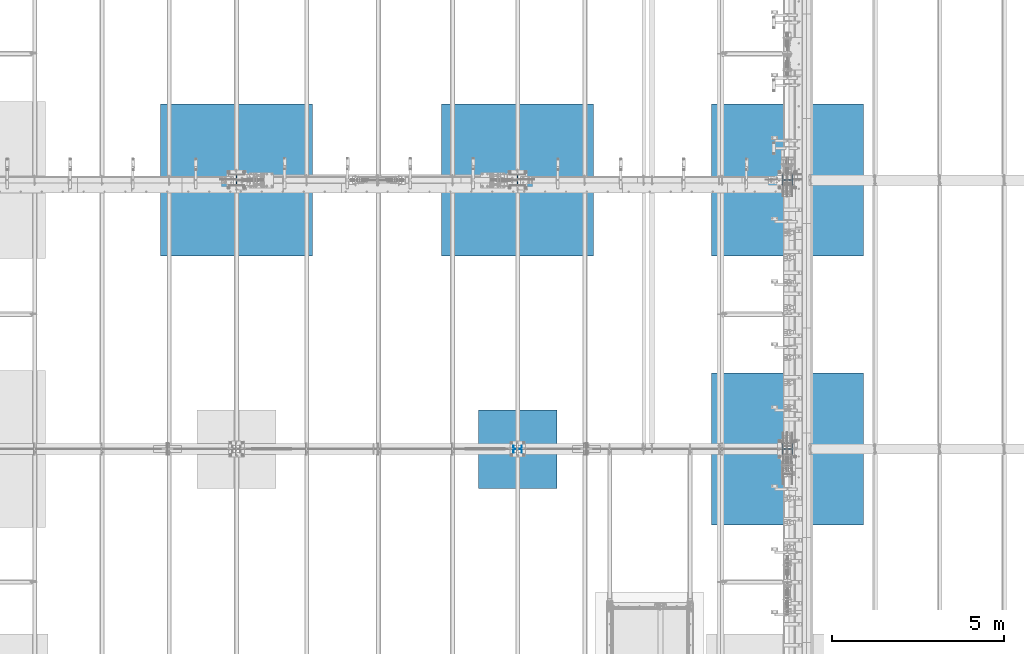
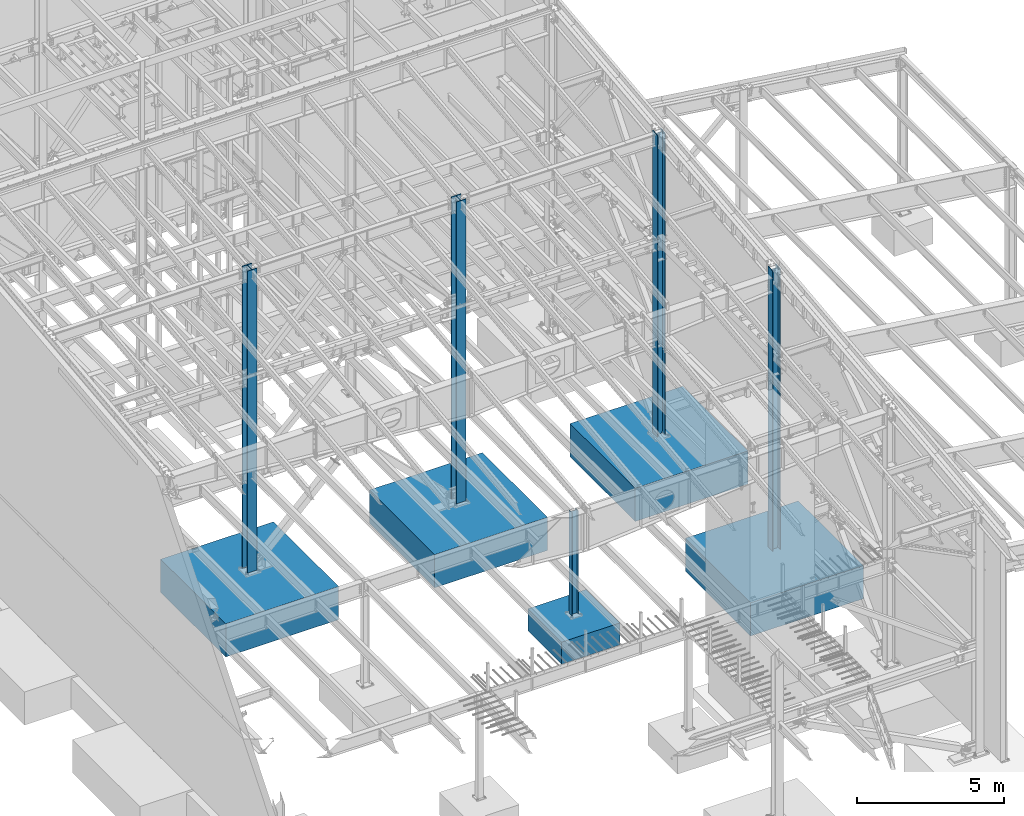
# One storey, part 359 of 1179: 10 columns, 10 elements without a shape of their own.
"""IFC2X3 building model written with IfcOpenShell, lengths in millimetres."""

import ifcopenshell
import ifcopenshell.guid

model = None  # the IFC model being written
_history = None  # IfcOwnerHistory: only IFC2X3 demands one
_inside = {}  # id of a spatial element -> (the spatial element, [elements in it])
_under = {}  # id of a project, library or spatial element -> (it, [spatial elements below it])
_declared = {}  # id of a project -> (the project, [libraries it declares])
_typed = {}  # id of a type object -> (the type object, [elements of that type])
_made_of = {}  # id of a material, layer set ... -> (it, [elements and type objects made of it])


def new_model(schema):
    """Start an empty IFC model of exactly this schema.

    Asked for "IFC4X3", IfcOpenShell would pick the latest addendum, in which some entities
    have other attributes; the version numbers below select the first issue.
    IFC2X3 requires an IfcOwnerHistory on every rooted entity: one is made here for all.
    """
    global model, _history
    if schema == "IFC4X3":
        model = ifcopenshell.file(schema_version=(4, 3, 0, 0))
    else:
        model = ifcopenshell.file(schema=schema)
    _inside.clear()
    _under.clear()
    _declared.clear()
    _typed.clear()
    _made_of.clear()
    _history = None
    if model.schema == "IFC2X3":
        org = make("IfcOrganization", Name="unknown")
        user = make(
            "IfcPersonAndOrganization",
            ThePerson=make("IfcPerson", FamilyName="unknown"),
            TheOrganization=org,
        )
        app = make(
            "IfcApplication",
            ApplicationDeveloper=org,
            Version="unknown",
            ApplicationFullName="unknown",
            ApplicationIdentifier="unknown",
        )
        _history = make(
            "IfcOwnerHistory",
            OwningUser=user,
            OwningApplication=app,
            ChangeAction="ADDED",
            CreationDate=0,
        )
    return model


def make(cls, **values):
    """One entity of the class cls with the attributes given. An attribute that is None is left unset."""
    return model.create_entity(
        cls, **{name: value for name, value in values.items() if value is not None}
    )


def rooted(cls, **values):
    """An entity with a GlobalId (a new one), such as an element, a storey or a relation."""
    return make(cls, GlobalId=ifcopenshell.guid.new(), OwnerHistory=_history, **values)


def si_unit(unit_type, name, prefix=None):
    """IfcSIUnit, for example si_unit("LENGTHUNIT", "METRE", prefix="MILLI")."""
    return make("IfcSIUnit", UnitType=unit_type, Prefix=prefix, Name=name)


def assignment(units):
    """IfcUnitAssignment: the units of a project."""
    return None if units is None else make("IfcUnitAssignment", Units=units)


def point(xyz):
    """IfcCartesianPoint."""
    return None if xyz is None else make("IfcCartesianPoint", Coordinates=xyz)


def direction(xyz):
    """IfcDirection."""
    return None if xyz is None else make("IfcDirection", DirectionRatios=xyz)


def frame(location, z_axis=None, x_axis=None):
    """IfcAxis2Placement3D, a coordinate frame: its origin and axes. An axis left out is left unset."""
    return make(
        "IfcAxis2Placement3D",
        Location=point(location),
        Axis=direction(z_axis),
        RefDirection=direction(x_axis),
    )


def origin_with_axes():
    """The frame at (0, 0, 0) with the z axis (0, 0, 1) and the x axis (1, 0, 0) written out."""
    return frame((0.0, 0.0, 0.0), z_axis=(0.0, 0.0, 1.0), x_axis=(1.0, 0.0, 0.0))


def place(relative_to, where):
    """IfcLocalPlacement: puts the frame where relative to a parent placement (None: the world)."""
    return make(
        "IfcLocalPlacement", PlacementRelTo=relative_to, RelativePlacement=where
    )


def context(
    kind, dimensions, precision=None, world=None, true_north=None, identifier=None
):
    """IfcGeometricRepresentationContext, for example the 3D "Model" context."""
    return make(
        "IfcGeometricRepresentationContext",
        ContextIdentifier=identifier,
        ContextType=kind,
        CoordinateSpaceDimension=dimensions,
        Precision=precision,
        WorldCoordinateSystem=world,
        TrueNorth=true_north,
    )


def subcontext(parent, identifier, kind, view, scale=None):
    """IfcGeometricRepresentationSubContext, for example "Body" below "Model"."""
    return make(
        "IfcGeometricRepresentationSubContext",
        ContextIdentifier=identifier,
        ContextType=kind,
        ParentContext=parent,
        TargetScale=scale,
        TargetView=view,
    )


def project(units=None, contexts=None):
    """IfcProject with its units and contexts."""
    return rooted(
        "IfcProject",
        Name="project",
        RepresentationContexts=contexts,
        UnitsInContext=assignment(units),
    )


def spatial(cls, under=None, at=None, **own):
    """A site, building, storey or space (cls), placed at a placement, below another one or the project."""
    s = rooted(cls, ObjectPlacement=at, **own)
    if under is not None:
        _under.setdefault(under.id(), (under, []))[1].append(s)
    return s


def faces_of(points, faces, orient=None, outer=None):
    """IfcFace entities. A face is a list of loops; a loop is a list of indices into points, from 0.

    orient and outer hold one flag for each loop. By default every Orientation is true, the
    first loop of a face is its IfcFaceOuterBound and the others are IfcFaceBound.
    """
    made = []
    for i, loops in enumerate(faces):
        bounds = []
        for j, loop in enumerate(loops):
            is_outer = j == 0 if outer is None else outer[i][j]
            bounds.append(
                make(
                    "IfcFaceOuterBound" if is_outer else "IfcFaceBound",
                    Bound=make("IfcPolyLoop", Polygon=[points[k] for k in loop]),
                    Orientation=True if orient is None else orient[i][j],
                )
            )
        made.append(make("IfcFace", Bounds=bounds))
    return made


def faceted_brep(points, faces, orient=None, outer=None, voids=None):
    """IfcFacetedBrep: a solid bounded by flat faces; with voids (closed shells), ...WithVoids."""
    shared = [point(p) for p in points]
    hull = make("IfcClosedShell", CfsFaces=faces_of(shared, faces, orient, outer))
    if voids is None:
        return make("IfcFacetedBrep", Outer=hull)
    return make(
        "IfcFacetedBrepWithVoids",
        Outer=hull,
        Voids=[
            make(cls, CfsFaces=faces_of(shared, fs, o, b)) for cls, fs, o, b in voids
        ],
    )


def shape(context_of_items, identifier, shape_type, items):
    """IfcShapeRepresentation: the items that make up one representation, for example the "Body"."""
    return make(
        "IfcShapeRepresentation",
        ContextOfItems=context_of_items,
        RepresentationIdentifier=identifier,
        RepresentationType=shape_type,
        Items=items,
    )


def material(Name=None, Category=None):
    """IfcMaterial."""
    return make("IfcMaterial", Name=Name, Category=Category)


def made_of(thing, what):
    """Note that an element or type object is made of a material, layer set ...; save() writes the relation."""
    if what is not None:
        _made_of.setdefault(what.id(), (what, []))[1].append(thing)
    return thing


def type_object(cls, material=None, **own):
    """A type object (cls), such as IfcWallType, which elements share."""
    return made_of(rooted(cls, **own), material)


def element(
    cls,
    number,
    at=None,
    inside=None,
    cuts=None,
    type_object=None,
    material=None,
    context=None,
    identifier="Body",
    shape_type=None,
    held_by="IfcProductDefinitionShape",
    body=None,
    shapes=None,
    **own,
):
    """One element of the class cls, such as IfcWall. Its Tag is "e" and its number.

    at: its placement. inside: the storey or other place that contains it. cuts: it is an
    opening in that element (IfcRelVoidsElement). A single representation is given by context,
    identifier, shape_type and body (its items); several are given by shapes. held_by: the class
    of the entity that holds the representations. save() writes the other relations.
    """
    e = rooted(cls, Tag="e%d" % number, ObjectPlacement=at, **own)
    if body is not None:
        shapes = [shape(context, identifier, shape_type, body)]
    if shapes is not None:
        e.Representation = make(held_by, Representations=shapes)
    if inside is not None:
        _inside.setdefault(inside.id(), (inside, []))[1].append(e)
    if cuts is not None:
        rooted(
            "IfcRelVoidsElement", RelatingBuildingElement=cuts, RelatedOpeningElement=e
        )
    if type_object is not None:
        _typed.setdefault(type_object.id(), (type_object, []))[1].append(e)
    return made_of(e, material)


def aggregate(whole, parts):
    """IfcRelAggregates: a whole, such as a stair, and the parts it consists of."""
    return rooted("IfcRelAggregates", RelatingObject=whole, RelatedObjects=parts)


def save(model, path):
    """Write the relations noted so far, then the file.

    IfcRelAggregates (storeys below a building ...), IfcRelContainedInSpatialStructure (elements
    in a storey), IfcRelDefinesByType, IfcRelAssociatesMaterial and IfcRelDeclares: one each for
    every whole, place, type object, material and project.
    """
    for whole, parts in _under.values():
        aggregate(whole, parts)
    for where, things in _inside.values():
        rooted(
            "IfcRelContainedInSpatialStructure",
            RelatedElements=things,
            RelatingStructure=where,
        )
    for kind, things in _typed.values():
        rooted("IfcRelDefinesByType", RelatedObjects=things, RelatingType=kind)
    for what, things in _made_of.values():
        rooted("IfcRelAssociatesMaterial", RelatedObjects=things, RelatingMaterial=what)
    for by, libraries in _declared.values():
        rooted("IfcRelDeclares", RelatingContext=by, RelatedDefinitions=libraries)
    model.write(path)


model = new_model("IFC2X3")

# Units and contexts
model_context = context("Model", 3, precision=1e-05, world=origin_with_axes())
body_context = subcontext(model_context, "Body", "Model", "MODEL_VIEW")
ifc_project = project(units=[si_unit("LENGTHUNIT", "METRE", prefix="MILLI"), si_unit("AREAUNIT", "SQUARE_METRE"), si_unit("VOLUMEUNIT", "CUBIC_METRE"), si_unit("MASSUNIT", "GRAM", prefix="KILO"), si_unit("TIMEUNIT", "SECOND"), si_unit("PLANEANGLEUNIT", "RADIAN"), si_unit("SOLIDANGLEUNIT", "STERADIAN"), si_unit("THERMODYNAMICTEMPERATUREUNIT", "DEGREE_CELSIUS"), si_unit("LUMINOUSINTENSITYUNIT", "LUMEN")], contexts=[model_context])

# Site, building, storey
site_placement = place(None, origin_with_axes())
site = spatial("IfcSite", under=ifc_project, at=site_placement, CompositionType="ELEMENT")
building_placement = place(site_placement, origin_with_axes())
building = spatial("IfcBuilding", under=site, at=building_placement, Name="Undefined", CompositionType="ELEMENT")
storey_placement = place(building_placement, origin_with_axes())
storey = spatial("IfcBuildingStorey", under=building, at=storey_placement, Name="Undefined", CompositionType="ELEMENT", Elevation=0.0)

# Assembly, column
assembly_1_placement = place(storey_placement, origin_with_axes())
assembly_1 = element("IfcElementAssembly", 1, at=assembly_1_placement, inside=storey, Name="FOOTING", AssemblyPlace="NOTDEFINED", PredefinedType="REINFORCEMENT_UNIT")
ifc_material_1 = material(Name="CONCRETE/3000")
column_type_1 = type_object("IfcColumnType", PredefinedType="NOTDEFINED")
column_1_placement = place(assembly_1_placement, frame((16459.2, 19227.8, -1168.4), z_axis=(-1.0, 0.0, 0.0), x_axis=(0.0, 0.0, 1.0)))
column_1 = element("IfcColumn", 2, at=column_1_placement, type_object=column_type_1, material=ifc_material_1, Name="FOOTING", context=body_context, shape_type="Brep", body=[
    faceted_brep([(0.0, 1143.0, -1143.0), (0.0, 1143.0, 1143.0), (914.4, 1143.0, 1143.0), (914.4, 1143.0, -1143.0), (0.0, -1143.0, 1143.0), (914.4, -1143.0, 1143.0), (0.0, -1143.0, -1143.0), (914.4, -1143.0, -1143.0)], [[[0, 1, 2, 3]], [[1, 4, 5, 2]], [[4, 6, 7, 5]], [[6, 0, 3, 7]], [[5, 7, 3, 2]], [[6, 4, 1, 0]]]),
])
aggregate(assembly_1, [column_1])

assembly_2_placement = place(storey_placement, origin_with_axes())
assembly_2 = element("IfcElementAssembly", 3, at=assembly_2_placement, inside=storey, Name="FOOTING", AssemblyPlace="NOTDEFINED", PredefinedType="REINFORCEMENT_UNIT")
column_type_2 = type_object("IfcColumnType", PredefinedType="NOTDEFINED")
column_2_placement = place(assembly_2_placement, frame((16459.2, 27051.0, -1727.2), z_axis=(-1.0, 0.0, 0.0), x_axis=(0.0, 0.0, 1.0)))
column_2 = element("IfcColumn", 4, at=column_2_placement, type_object=column_type_2, material=ifc_material_1, Name="FOOTING", context=body_context, shape_type="Brep", body=[
    faceted_brep([(0.0, 2209.8, -2209.8), (0.0, 2209.8, 2209.8), (1371.6, 2209.8, 2209.8), (1371.6, 2209.8, -2209.8), (0.0, -2209.8, 2209.8), (1371.6, -2209.8, 2209.8), (0.0, -2209.8, -2209.8), (1371.6, -2209.8, -2209.8)], [[[0, 1, 2, 3]], [[1, 4, 5, 2]], [[4, 6, 7, 5]], [[6, 0, 3, 7]], [[5, 7, 3, 2]], [[6, 4, 1, 0]]]),
])
aggregate(assembly_2, [column_2])

assembly_3_placement = place(storey_placement, origin_with_axes())
assembly_3 = element("IfcElementAssembly", 5, at=assembly_3_placement, inside=storey, Name="FOOTING", AssemblyPlace="NOTDEFINED", PredefinedType="REINFORCEMENT_UNIT")
column_3_placement = place(assembly_3_placement, frame((8280.4, 27051.0, -1727.2), z_axis=(-1.0, 0.0, 0.0), x_axis=(0.0, 0.0, 1.0)))
column_3 = element("IfcColumn", 6, at=column_3_placement, type_object=column_type_2, material=ifc_material_1, Name="FOOTING", context=body_context, shape_type="Brep", body=[
    faceted_brep([(0.0, 2209.8, -2209.8), (0.0, 2209.8, 2209.8), (1371.6, 2209.8, 2209.8), (1371.6, 2209.8, -2209.8), (0.0, -2209.8, 2209.8), (1371.6, -2209.8, 2209.8), (0.0, -2209.8, -2209.8), (1371.6, -2209.8, -2209.8)], [[[0, 1, 2, 3]], [[1, 4, 5, 2]], [[4, 6, 7, 5]], [[6, 0, 3, 7]], [[5, 7, 3, 2]], [[6, 4, 1, 0]]]),
])
aggregate(assembly_3, [column_3])

assembly_4_placement = place(storey_placement, origin_with_axes())
assembly_4 = element("IfcElementAssembly", 7, at=assembly_4_placement, inside=storey, Name="FOOTING", AssemblyPlace="NOTDEFINED", PredefinedType="REINFORCEMENT_UNIT")
column_4_placement = place(assembly_4_placement, frame((24307.8, 19227.8, -1727.2), z_axis=(-1.0, 0.0, 0.0), x_axis=(0.0, 0.0, 1.0)))
column_4 = element("IfcColumn", 8, at=column_4_placement, type_object=column_type_2, material=ifc_material_1, Name="FOOTING", context=body_context, shape_type="Brep", body=[
    faceted_brep([(0.0, 2209.8, -2209.8), (0.0, 2209.8, 2209.8), (1371.6, 2209.8, 2209.8), (1371.6, 2209.8, -2209.8), (0.0, -2209.8, 2209.8), (1371.6, -2209.8, 2209.8), (0.0, -2209.8, -2209.8), (1371.6, -2209.8, -2209.8)], [[[0, 1, 2, 3]], [[1, 4, 5, 2]], [[4, 6, 7, 5]], [[6, 0, 3, 7]], [[5, 7, 3, 2]], [[6, 4, 1, 0]]]),
])
aggregate(assembly_4, [column_4])

assembly_5_placement = place(storey_placement, origin_with_axes())
assembly_5 = element("IfcElementAssembly", 9, at=assembly_5_placement, inside=storey, Name="FOOTING", AssemblyPlace="NOTDEFINED", PredefinedType="REINFORCEMENT_UNIT")
column_5_placement = place(assembly_5_placement, frame((24307.8, 27051.0, -1727.2), z_axis=(-1.0, 0.0, 0.0), x_axis=(0.0, 0.0, 1.0)))
column_5 = element("IfcColumn", 10, at=column_5_placement, type_object=column_type_2, material=ifc_material_1, Name="FOOTING", context=body_context, shape_type="Brep", body=[
    faceted_brep([(0.0, 2209.8, -2209.8), (0.0, 2209.8, 2209.8), (1371.6, 2209.8, 2209.8), (1371.6, 2209.8, -2209.8), (0.0, -2209.8, 2209.8), (1371.6, -2209.8, 2209.8), (0.0, -2209.8, -2209.8), (1371.6, -2209.8, -2209.8)], [[[0, 1, 2, 3]], [[1, 4, 5, 2]], [[4, 6, 7, 5]], [[6, 0, 3, 7]], [[5, 7, 3, 2]], [[6, 4, 1, 0]]]),
])
aggregate(assembly_5, [column_5])

assembly_6_placement = place(storey_placement, origin_with_axes())
assembly_6 = element("IfcElementAssembly", 11, at=assembly_6_placement, inside=storey, Name="COLUMN", AssemblyPlace="NOTDEFINED", PredefinedType="RIGID_FRAME")
ifc_material_2 = material(Name="STEEL/A992")
column_type_3 = type_object("IfcColumnType", Name="W12X79", PredefinedType="NOTDEFINED")
column_6_placement = place(assembly_6_placement, frame((24307.8, 19227.8, -355.6), z_axis=(-1.0, 0.0, 0.0), x_axis=(0.0, 0.0, 1.0)))
column_6 = element("IfcColumn", 12, at=column_6_placement, type_object=column_type_3, material=ifc_material_2, Name="COLUMN", ObjectType="W12X79", context=body_context, shape_type="Brep", body=[
    faceted_brep([(160.223581529497, -153.987499999999, 157.1625), (160.223581529497, 153.987499999999, 157.1625), (149.225002356772, 153.987499999999, 138.1125), (149.225002356772, 6.35000012494493, 138.1125), (148.995793121516, 6.35000012313685, 137.715499999996), (148.995793121516, -6.34999999999854, 137.715499999996), (149.225002356772, -6.34999999999854, 138.1125), (149.225002356772, -153.987499999999, 138.1125), (188.913, -6.34999999999854, 137.715499999996), (188.913, 6.35000008947463, 137.715499999996), (208.49066058208, 6.35000008789211, 131.2871410688), (208.49066058208, -6.34999999999854, 131.2871410688), (212.873373738864, 6.35000008718271, 128.290736246858), (212.873373738864, -6.34999999999854, 128.290736246858), (214.971292158606, 6.35000008606585, 123.413713099926), (214.971292158606, -6.34999999999854, 123.413713099926), (214.132634973196, 6.3500000848835, 118.171264187733), (214.132634973196, -6.34999999999854, 118.171264187733), (210.617956026487, 6.35000008400311, 114.192112472459), (210.617956026487, -6.34999999999854, 114.192112472459), (205.519195059062, 6.35000008370116, 112.712499999996), (205.519195059062, -6.34999999999854, 112.712499999996), (147.032344061553, 6.35000011347802, 112.712499999996), (139.700000000001, -6.34999999999854, 112.712499999996), (147.032344061555, 6.35000001149092, -112.712500000003), (139.700000000001, -6.34999999999854, -112.712500000003), (205.519195059063, 6.3500000365857, -112.712500000003), (205.519195059063, -6.34999999999854, -112.712500000003), (210.617956026486, 6.35000003621826, -114.192112472468), (210.617956026486, -6.34999999999854, -114.192112472468), (214.132634973195, 6.35000003529422, -118.171264187741), (214.132634973195, -6.34999999999854, -118.171264187741), (214.971292158605, 6.35000003410096, -123.413713099934), (214.971292158605, -6.34999999999854, -123.413713099934), (212.873373738863, 6.35000003300956, -128.290736246865), (212.873373738863, -6.34999999999854, -128.290736246865), (208.49066058208, 6.35000003235837, -131.287141068808), (208.49066058208, -6.34999999999854, -131.287141068808), (188.913, 6.35000003102323, -137.715500000003), (188.913, -6.34999999999854, -137.715500000003), (148.99620123074, 6.35000000162472, -137.715500000003), (148.99620123074, -6.34999999999854, -137.715500000003), (11747.1708316716, 6.34999999999854, -138.112499999999), (11776.0127002285, 6.34999999999854, -138.112499999999), (11792.6861073463, 153.987499999999, -138.112499999999), (149.225402461476, 153.987499999999, -138.1125), (149.225402461477, 6.34999999999854, -138.1125), (11757.9050215307, -153.987499999999, -138.112499999999), (11757.9050215307, -153.987499999999, -157.162499999999), (11792.6861073463, 153.987499999999, -157.162499999999), (11774.5784286485, -6.34999999999854, -138.112499999999), (149.225402461476, -153.987499999999, -138.1125), (160.223597538519, -153.987499999999, -157.1625), (160.223597538519, 153.987499999999, -157.1625), (149.225402461476, -6.34999999999854, -138.1125), (11745.7365600947, -6.34999999999854, -138.112499999999), (11747.1708316716, 6.35000000020227, 138.112499999999), (11745.7365600947, -6.34999999999854, 138.112499999999), (11775.9031726808, 6.35000002950983, 138.112499999999), (11774.5784286485, -6.34999999999854, 138.112499999999), (11792.6861073463, 153.987499999999, 138.112499999999), (11792.6861073463, 153.987499999999, 157.162499999999), (11757.9050215307, -153.987499999999, 157.162499999999), (11757.9050215307, -153.987499999999, 138.112499999999)], [[[0, 1, 2, 3, 4, 5, 6, 7]], [[8, 9, 10, 11]], [[11, 10, 12, 13]], [[13, 12, 14, 15]], [[15, 14, 16, 17]], [[17, 16, 18, 19]], [[19, 18, 20, 21]], [[21, 20, 22, 23]], [[24, 25, 23, 22]], [[25, 24, 26, 27]], [[27, 26, 28, 29]], [[29, 28, 30, 31]], [[31, 30, 32, 33]], [[33, 32, 34, 35]], [[35, 34, 36, 37]], [[37, 36, 38, 39]], [[39, 38, 40, 41]], [[42, 43, 44, 45, 46]], [[47, 48, 49, 44, 43, 50]], [[48, 47, 51, 52]], [[49, 48, 52, 53]], [[44, 49, 53, 45]], [[52, 51, 54, 41, 40, 46, 45, 53]], [[47, 50, 55, 54, 51]], [[43, 42, 55, 50]], [[56, 57, 55, 42]], [[58, 59, 57, 56]], [[60, 61, 62, 63, 59, 58]], [[63, 62, 0, 7]], [[57, 59, 63, 7, 6]], [[8, 11, 13, 15, 17, 19, 21, 23, 25, 27, 29, 31, 33, 35, 37, 39, 41, 54, 55, 57, 6, 5]], [[9, 8, 5, 4]], [[56, 42, 46, 40, 38, 36, 34, 32, 30, 28, 26, 24, 22, 20, 18, 16, 14, 12, 10, 9, 4, 3]], [[60, 58, 56, 3, 2]], [[61, 60, 2, 1]], [[62, 61, 1, 0]]]),
])
aggregate(assembly_6, [column_6])

assembly_7_placement = place(storey_placement, origin_with_axes())
assembly_7 = element("IfcElementAssembly", 13, at=assembly_7_placement, inside=storey, Name="COLUMN", AssemblyPlace="NOTDEFINED", PredefinedType="RIGID_FRAME")
column_7_placement = place(assembly_7_placement, frame((24307.8, 27051.0, -355.6), z_axis=(-1.0, 0.0, 0.0), x_axis=(0.0, 0.0, 1.0)))
column_7 = element("IfcColumn", 14, at=column_7_placement, type_object=column_type_3, material=ifc_material_2, Name="COLUMN", ObjectType="W12X79", context=body_context, shape_type="Brep", body=[
    faceted_brep([(160.223581529497, -153.987499999999, 157.1625), (160.223581529497, 153.987499999999, 157.1625), (149.225002356772, 153.987499999999, 138.1125), (149.225002356772, 6.35000012494493, 138.1125), (148.995793121516, 6.35000012313685, 137.715499999996), (148.995793121516, -6.34999999999854, 137.715499999996), (149.225002356772, -6.34999999999854, 138.1125), (149.225002356772, -153.987499999999, 138.1125), (188.913, -6.34999999999854, 137.715499999996), (188.913, 6.35000008947463, 137.715499999996), (208.49066058208, 6.35000008789211, 131.2871410688), (208.49066058208, -6.34999999999854, 131.2871410688), (212.873373738864, 6.35000008718271, 128.290736246858), (212.873373738864, -6.34999999999854, 128.290736246858), (214.971292158606, 6.35000008606585, 123.413713099926), (214.971292158606, -6.34999999999854, 123.413713099926), (214.132634973196, 6.3500000848835, 118.171264187733), (214.132634973196, -6.34999999999854, 118.171264187733), (210.617956026487, 6.35000008400311, 114.192112472459), (210.617956026487, -6.34999999999854, 114.192112472459), (205.519195059062, 6.35000008370116, 112.712499999996), (205.519195059062, -6.34999999999854, 112.712499999996), (139.700000000001, 6.34999999999854, 112.7125), (147.032309983244, -6.35000007376584, 112.7125), (139.700000000001, 6.34999999999854, -112.7125), (147.032309983244, -6.35000000747095, -112.7125), (205.519195059063, 6.3500000365857, -112.712500000003), (205.519195059063, -6.34999999999854, -112.712500000003), (210.617956026486, 6.35000003621826, -114.192112472468), (210.617956026486, -6.34999999999854, -114.192112472468), (214.132634973195, 6.35000003529422, -118.171264187741), (214.132634973195, -6.34999999999854, -118.171264187741), (214.971292158605, 6.35000003410096, -123.413713099934), (214.971292158605, -6.34999999999854, -123.413713099934), (212.873373738863, 6.35000003300956, -128.290736246865), (212.873373738863, -6.34999999999854, -128.290736246865), (208.49066058208, 6.35000003235837, -131.287141068808), (208.49066058208, -6.34999999999854, -131.287141068808), (188.913, 6.35000003102323, -137.715500000003), (188.913, -6.34999999999854, -137.715500000003), (148.99620123074, 6.35000000162472, -137.715500000003), (148.99620123074, -6.34999999999854, -137.715500000003), (12631.1820588324, 6.34999999999854, -138.112499999999), (12659.9143998381, 6.34999999999854, -138.112499999999), (12676.5654241987, 153.987499999999, -138.112499999999), (149.225402461476, 153.987499999999, -138.1125), (149.225402461477, 6.34999999999854, -138.1125), (12641.8310292959, -153.987499999999, -138.112499999999), (12641.8310292959, -153.987499999999, -157.162499999999), (12676.5654241987, 153.987499999999, -157.162499999999), (12658.4820536565, -6.34999999999854, -138.112499999999), (149.225402461476, -153.987499999999, -138.1125), (160.223597538519, -153.987499999999, -157.1625), (160.223597538519, 153.987499999999, -157.1625), (149.225402461476, -6.34999999999854, -138.1125), (12629.7477872555, -6.34999999999854, -138.112499999999), (12631.1820588324, 6.34999999999854, 138.112499999999), (12629.7477872555, -6.35000000018772, 138.112499999999), (12659.9143998415, 6.34999999961292, 138.112499999996), (12658.4820536565, -6.34999999999854, 138.112499999999), (12676.5654241987, 153.987499999999, 138.112499999999), (12676.5654241987, 153.987499999999, 157.162499999999), (12641.8310292959, -153.987499999999, 157.162499999999), (12641.8310292959, -153.987499999999, 138.112499999999)], [[[0, 1, 2, 3, 4, 5, 6, 7]], [[8, 9, 10, 11]], [[11, 10, 12, 13]], [[13, 12, 14, 15]], [[15, 14, 16, 17]], [[17, 16, 18, 19]], [[19, 18, 20, 21]], [[21, 20, 22, 23]], [[24, 25, 23, 22]], [[25, 24, 26, 27]], [[27, 26, 28, 29]], [[29, 28, 30, 31]], [[31, 30, 32, 33]], [[33, 32, 34, 35]], [[35, 34, 36, 37]], [[37, 36, 38, 39]], [[39, 38, 40, 41]], [[42, 43, 44, 45, 46]], [[47, 48, 49, 44, 43, 50]], [[48, 47, 51, 52]], [[49, 48, 52, 53]], [[44, 49, 53, 45]], [[52, 51, 54, 41, 40, 46, 45, 53]], [[47, 50, 55, 54, 51]], [[43, 42, 55, 50]], [[56, 57, 55, 42]], [[58, 59, 57, 56]], [[60, 61, 62, 63, 59, 58]], [[63, 62, 0, 7]], [[57, 59, 63, 7, 6]], [[8, 11, 13, 15, 17, 19, 21, 23, 25, 27, 29, 31, 33, 35, 37, 39, 41, 54, 55, 57, 6, 5]], [[9, 8, 5, 4]], [[56, 42, 46, 40, 38, 36, 34, 32, 30, 28, 26, 24, 22, 20, 18, 16, 14, 12, 10, 9, 4, 3]], [[60, 58, 56, 3, 2]], [[61, 60, 2, 1]], [[62, 61, 1, 0]]]),
])
aggregate(assembly_7, [column_7])

assembly_8_placement = place(storey_placement, origin_with_axes())
assembly_8 = element("IfcElementAssembly", 15, at=assembly_8_placement, inside=storey, Name="COLUMN", AssemblyPlace="NOTDEFINED", PredefinedType="RIGID_FRAME")
column_type_4 = type_object("IfcColumnType", Name="W10X39", PredefinedType="NOTDEFINED")
column_8_placement = place(assembly_8_placement, frame((16459.2, 19227.8, -355.6), z_axis=(-1.0, 0.0, 0.0), x_axis=(0.0, 0.0, 1.0)))
column_8 = element("IfcColumn", 16, at=column_8_placement, type_object=column_type_4, material=ifc_material_2, Name="COLUMN", ObjectType="W10X39", context=body_context, shape_type="Brep", body=[
    faceted_brep([(190.5, 101.599999999999, -125.412499999999), (190.5, 101.599999999999, -112.712500000001), (4457.7, 101.599999999999, -112.712500000001), (4457.7, 101.599999999999, -125.412499999999), (190.5, 3.96875, -112.712500000001), (4457.7, 3.96875, -112.712500000001), (190.5, 3.96875, 112.7125), (4457.7, 3.96875, 112.7125), (190.5, 101.599999999999, 112.7125), (4457.7, 101.599999999999, 112.7125), (190.5, 101.599999999999, 125.4125), (4457.7, 101.599999999999, 125.4125), (190.5, -101.599999999999, 125.4125), (4457.7, -101.599999999999, 125.4125), (190.5, -101.599999999999, 112.7125), (4457.7, -101.599999999999, 112.7125), (190.5, -3.96875, 112.7125), (4457.7, -3.96875, 112.7125), (190.5, -3.96875, -112.712500000001), (4457.7, -3.96875, -112.712500000001), (190.5, -101.599999999999, -112.712500000001), (4457.7, -101.599999999999, -112.712500000001), (190.5, -101.599999999999, -125.412499999999), (4457.7, -101.599999999999, -125.412499999999)], [[[0, 1, 2, 3]], [[1, 4, 5, 2]], [[4, 6, 7, 5]], [[6, 8, 9, 7]], [[8, 10, 11, 9]], [[10, 12, 13, 11]], [[12, 14, 15, 13]], [[14, 16, 17, 15]], [[16, 18, 19, 17]], [[18, 20, 21, 19]], [[20, 22, 23, 21]], [[22, 0, 3, 23]], [[5, 7, 9, 11, 13, 15, 17, 19, 21, 23, 3, 2]], [[22, 20, 18, 16, 14, 12, 10, 8, 6, 4, 1, 0]]]),
])
aggregate(assembly_8, [column_8])

assembly_9_placement = place(storey_placement, origin_with_axes())
assembly_9 = element("IfcElementAssembly", 17, at=assembly_9_placement, inside=storey, Name="COLUMN", AssemblyPlace="NOTDEFINED", PredefinedType="RIGID_FRAME")
column_type_5 = type_object("IfcColumnType", Name="W14X109", PredefinedType="NOTDEFINED")
column_9_placement = place(assembly_9_placement, frame((16459.2, 27051.0, -355.6), z_axis=(0.0, 1.0, 0.0), x_axis=(0.0, 0.0, 1.0)))
column_9 = element("IfcColumn", 18, at=column_9_placement, type_object=column_type_5, material=ifc_material_2, Name="COLUMN", ObjectType="W14X109", context=body_context, shape_type="Brep", body=[
    faceted_brep([(162.056584748065, -185.737499999999, 182.5625), (162.056584748065, 185.737499999999, 182.5625), (149.2249991382, 185.737499999999, 160.337500000001), (149.224999138197, 6.35001194876168, 160.337500000001), (148.995791512231, 6.35001180231484, 159.940500000001), (148.995791512231, -6.34999999999854, 159.940500000001), (149.2249991382, -6.34999999999854, 160.337500000001), (149.2249991382, -185.737499999999, 160.337500000001), (12659.121875, 185.737499999999, -182.5625), (12659.121875, -185.737499999999, -182.5625), (162.056598622599, -185.737499999999, -182.5625), (162.056598622599, 185.737499999999, -182.5625), (12659.121875, -185.737499999999, -160.337500000001), (149.2254013774, -185.737499999999, -160.337500000001), (12659.121875, -6.34999999999854, -160.337500000001), (149.2254013774, -6.34999999999854, -160.337500000001), (196.85, -6.34999999999854, 159.940500000001), (196.85, 6.3500085426349, 159.940500000001), (216.427660582082, 6.35000841315195, 153.512141068804), (216.427660582082, -6.34999999999854, 153.512141068804), (220.810373738865, 6.35000835514074, 150.51573624686), (220.810373738865, -6.34999999999854, 150.51573624686), (222.908292158607, 6.35000826321266, 145.638713099932), (222.908292158607, -6.34999999999854, 145.638713099932), (222.069634973197, 6.35000816592947, 140.396264187737), (222.069634973197, -6.34999999999854, 140.396264187737), (218.554956026489, 6.35000809351186, 136.417112472463), (218.554956026489, -6.34999999999854, 136.417112472463), (213.456195059064, 6.35000806846074, 134.9375), (213.456195059064, -6.34999999999854, 134.9375), (147.032355336045, 6.35001100425143, 134.9375), (139.7, -6.34999999999854, 134.9375), (147.032355336045, 6.35000094660063, -134.9375), (139.7, -6.34999999999854, -134.9375), (213.456195059064, 6.35000342929197, -134.9375), (213.456195059064, -6.34999999999854, -134.9375), (218.554956026488, 6.35000339928592, -136.417112472463), (218.554956026488, -6.34999999999854, -136.417112472463), (222.069634973196, 6.35000332345953, -140.396264187737), (222.069634973196, -6.34999999999854, -140.396264187737), (222.908292158606, 6.35000322537235, -145.638713099932), (222.908292158606, -6.34999999999854, -145.638713099932), (220.810373738864, 6.35000313549608, -150.515736246864), (220.810373738864, -6.34999999999854, -150.515736246864), (216.427660582081, 6.35000308175586, -153.512141068804), (216.427660582081, -6.34999999999854, -153.512141068804), (196.85, 6.35000297132137, -159.940500000001), (196.85, -6.34999999999854, -159.940500000001), (148.9962006887, 6.35000013134413, -159.940500000001), (148.9962006887, -6.34999999999854, -159.940500000001), (12659.121875, 6.34999999999854, -160.337500000001), (12659.121875, 185.737499999999, -160.337500000001), (149.2254013774, 185.737499999999, -160.337500000001), (149.225401377399, 6.34999999999854, -160.337500000001), (12659.121875, 6.34999999999854, 160.337500000001), (12659.121875, 185.737499999999, 160.337500000001), (12659.121875, 185.737499999999, 182.5625), (12659.121875, -185.737499999999, 182.5625), (12659.121875, -185.737499999999, 160.337500000001), (12659.121875, -6.34999999999854, 160.337500000001)], [[[0, 1, 2, 3, 4, 5, 6, 7]], [[8, 9, 10, 11]], [[9, 12, 13, 10]], [[12, 14, 15, 13]], [[16, 17, 18, 19]], [[19, 18, 20, 21]], [[21, 20, 22, 23]], [[23, 22, 24, 25]], [[25, 24, 26, 27]], [[27, 26, 28, 29]], [[29, 28, 30, 31]], [[32, 33, 31, 30]], [[33, 32, 34, 35]], [[35, 34, 36, 37]], [[37, 36, 38, 39]], [[39, 38, 40, 41]], [[41, 40, 42, 43]], [[43, 42, 44, 45]], [[45, 44, 46, 47]], [[47, 46, 48, 49]], [[50, 51, 52, 53]], [[10, 13, 15, 49, 48, 53, 52, 11]], [[51, 8, 11, 52]], [[50, 54, 55, 56, 57, 58, 59, 14, 12, 9, 8, 51]], [[58, 57, 0, 7]], [[59, 58, 7, 6]], [[16, 19, 21, 23, 25, 27, 29, 31, 33, 35, 37, 39, 41, 43, 45, 47, 49, 15, 14, 59, 6, 5]], [[17, 16, 5, 4]], [[54, 50, 53, 48, 46, 44, 42, 40, 38, 36, 34, 32, 30, 28, 26, 24, 22, 20, 18, 17, 4, 3]], [[55, 54, 3, 2]], [[56, 55, 2, 1]], [[57, 56, 1, 0]]]),
])
aggregate(assembly_9, [column_9])

assembly_10_placement = place(storey_placement, origin_with_axes())
assembly_10 = element("IfcElementAssembly", 19, at=assembly_10_placement, inside=storey, Name="COLUMN", AssemblyPlace="NOTDEFINED", PredefinedType="RIGID_FRAME")
column_10_placement = place(assembly_10_placement, frame((8280.4, 27051.0, -355.6), z_axis=(0.0, 1.0, 0.0), x_axis=(0.0, 0.0, 1.0)))
column_10 = element("IfcColumn", 20, at=column_10_placement, type_object=column_type_5, material=ifc_material_2, Name="COLUMN", ObjectType="W14X109", context=body_context, shape_type="Brep", body=[
    faceted_brep([(162.056584748065, -185.737499999999, 182.5625), (162.056584748065, 185.737499999999, 182.5625), (149.2249991382, 185.737499999999, 160.337500000001), (149.224999138197, 6.35001194876168, 160.337500000001), (148.995791512231, 6.35001180231484, 159.940500000001), (148.995791512231, -6.34999999999854, 159.940500000001), (149.2249991382, -6.34999999999854, 160.337500000001), (149.2249991382, -185.737499999999, 160.337500000001), (12659.121875, 185.737499999999, -182.5625), (12659.121875, -185.737499999999, -182.5625), (162.056598622599, -185.737499999999, -182.5625), (162.056598622599, 185.737499999999, -182.5625), (12659.121875, -185.737499999999, -160.337500000001), (149.2254013774, -185.737499999999, -160.337500000001), (12659.121875, -6.34999999999854, -160.337500000001), (149.2254013774, -6.34999999999854, -160.337500000001), (196.85, -6.34999999999854, 159.940500000001), (196.85, 6.3500085426349, 159.940500000001), (216.427660582082, 6.35000841315195, 153.512141068804), (216.427660582082, -6.34999999999854, 153.512141068804), (220.810373738865, 6.35000835514074, 150.51573624686), (220.810373738865, -6.34999999999854, 150.51573624686), (222.908292158607, 6.35000826321266, 145.638713099932), (222.908292158607, -6.34999999999854, 145.638713099932), (222.069634973197, 6.35000816592947, 140.396264187737), (222.069634973197, -6.34999999999854, 140.396264187737), (218.554956026489, 6.35000809351186, 136.417112472463), (218.554956026489, -6.34999999999854, 136.417112472463), (213.456195059064, 6.35000806846074, 134.9375), (213.456195059064, -6.34999999999854, 134.9375), (139.7, 6.35000000000036, 134.9375), (147.032355149431, -6.35001117261891, 134.9375), (139.7, 6.35000000000036, -134.9375), (147.032355149431, -6.35000096108524, -134.9375), (213.456195059064, 6.35000342929197, -134.9375), (213.456195059064, -6.34999999999854, -134.9375), (218.554956026488, 6.35000339928592, -136.417112472463), (218.554956026488, -6.34999999999854, -136.417112472463), (222.069634973196, 6.35000332345953, -140.396264187737), (222.069634973196, -6.34999999999854, -140.396264187737), (222.908292158606, 6.35000322537235, -145.638713099932), (222.908292158606, -6.34999999999854, -145.638713099932), (220.810373738864, 6.35000313549608, -150.515736246864), (220.810373738864, -6.34999999999854, -150.515736246864), (216.427660582081, 6.35000308175586, -153.512141068804), (216.427660582081, -6.34999999999854, -153.512141068804), (196.85, 6.35000297132137, -159.940500000001), (196.85, -6.34999999999854, -159.940500000001), (148.9962006887, 6.35000013134413, -159.940500000001), (148.9962006887, -6.34999999999854, -159.940500000001), (12659.121875, 6.34999999999854, -160.337500000001), (12659.121875, 185.737499999999, -160.337500000001), (149.2254013774, 185.737499999999, -160.337500000001), (149.225401377399, 6.34999999999854, -160.337500000001), (12659.121875, 6.34999999999854, 160.337500000001), (12659.121875, 185.737499999999, 160.337500000001), (12659.121875, 185.737499999999, 182.5625), (12659.121875, -185.737499999999, 182.5625), (12659.121875, -185.737499999999, 160.337500000001), (12659.121875, -6.34999999999854, 160.337500000001)], [[[0, 1, 2, 3, 4, 5, 6, 7]], [[8, 9, 10, 11]], [[9, 12, 13, 10]], [[12, 14, 15, 13]], [[16, 17, 18, 19]], [[19, 18, 20, 21]], [[21, 20, 22, 23]], [[23, 22, 24, 25]], [[25, 24, 26, 27]], [[27, 26, 28, 29]], [[29, 28, 30, 31]], [[32, 33, 31, 30]], [[33, 32, 34, 35]], [[35, 34, 36, 37]], [[37, 36, 38, 39]], [[39, 38, 40, 41]], [[41, 40, 42, 43]], [[43, 42, 44, 45]], [[45, 44, 46, 47]], [[47, 46, 48, 49]], [[50, 51, 52, 53]], [[10, 13, 15, 49, 48, 53, 52, 11]], [[51, 8, 11, 52]], [[50, 54, 55, 56, 57, 58, 59, 14, 12, 9, 8, 51]], [[58, 57, 0, 7]], [[59, 58, 7, 6]], [[16, 19, 21, 23, 25, 27, 29, 31, 33, 35, 37, 39, 41, 43, 45, 47, 49, 15, 14, 59, 6, 5]], [[17, 16, 5, 4]], [[54, 50, 53, 48, 46, 44, 42, 40, 38, 36, 34, 32, 30, 28, 26, 24, 22, 20, 18, 17, 4, 3]], [[55, 54, 3, 2]], [[56, 55, 2, 1]], [[57, 56, 1, 0]]]),
])
aggregate(assembly_10, [column_10])

save(model, "model.ifc")
